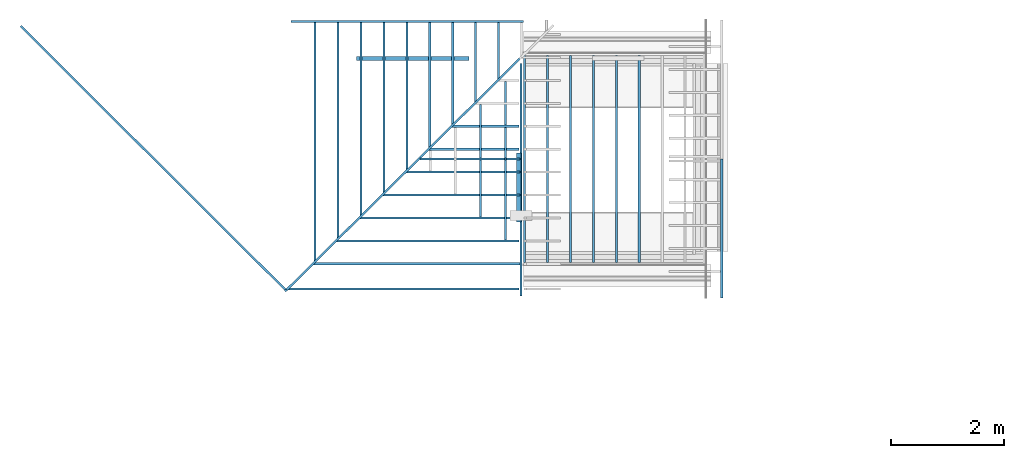
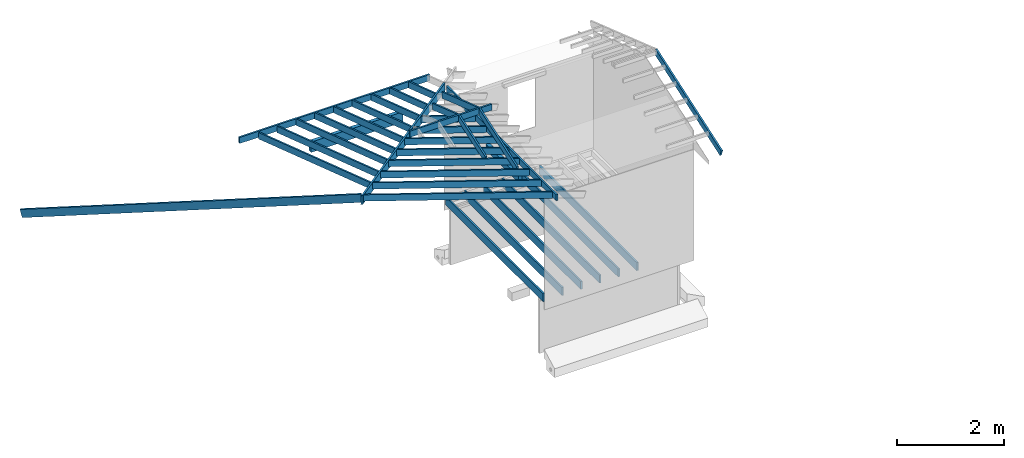
# Not in any storey, part 2 of 8: 35 beams.
"""IFC4 model written with IfcOpenShell, lengths in feet."""

from ifc_helpers import new_model, entity, si_unit, converted_unit, frame, origin_with_axes, origin_2d_with_axis, place, context, subcontext, project, rectangle, extrude, clip, halfspace, material, material_profile, profile_set, profile_usage, type_object, element, save


model = new_model("IFC4")

# Units and contexts
model_context = context("Model", 3, precision=1e-05, world=origin_with_axes())
plan_context = context("Plan", 2, precision=1e-05, world=origin_2d_with_axis())
context_of_model_1 = context(None, 3, precision=1e-05, world=origin_with_axes())
context_of_model_2 = context(None, 3, precision=1e-05, world=origin_with_axes())
body_context = subcontext(model_context, "Body", "Model", "MODEL_VIEW")
ifc_project = project(units=[converted_unit("PLANEANGLEUNIT", "degree", entity("IfcReal", 0.0174532925199433), si_unit("PLANEANGLEUNIT", "RADIAN"), dimensions=[0, 0, 0, 0, 0, 0, 0]), converted_unit("AREAUNIT", "square foot", entity("IfcReal", 0.09290304), si_unit("AREAUNIT", "SQUARE_METRE"), dimensions=[2, 0, 0, 0, 0, 0, 0]), converted_unit("LENGTHUNIT", "foot", entity("IfcReal", 0.3048), si_unit("LENGTHUNIT", "METRE"), dimensions=[1, 0, 0, 0, 0, 0, 0]), converted_unit("VOLUMEUNIT", "cubic foot", entity("IfcReal", 0.0283168467116885), si_unit("VOLUMEUNIT", "CUBIC_METRE"), dimensions=[3, 0, 0, 0, 0, 0, 0])], contexts=[model_context, plan_context, context_of_model_1, context_of_model_2])

# Beams
ifc_material_1 = material(Name="006")
ifc_material_profile_1 = material_profile(ifc_material_1, rectangle(XDim=0.125, YDim=0.604166686534882))
ifc_profile_set_1 = profile_set([ifc_material_profile_1])
ifc_profile_usage_1 = profile_usage(ifc_profile_set_1, cardinal=5)
beam_type_1 = type_object("IfcBeamType", Name="2x8", PredefinedType="BEAM", material=ifc_profile_set_1)
beam_1_placement = place(None, frame((-24.3661660221931, -5.03533664025034, 13.1159348124907), z_axis=(-0.690051735201045, 0.687267125403387, -0.226919591674655), x_axis=(-0.705675718596325, -0.708534953395779, 3.42501741274506e-08)))
element("IfcBeam", 1, at=beam_1_placement, type_object=beam_type_1, material=ifc_profile_usage_1, Name="Beam", context=body_context, shape_type="Clipping", body=[
    clip(extrude(rectangle(XDim=0.125, YDim=0.604166686534882), origin_with_axes(), (0.0, 0.0, 1.0), 22.830093170439), halfspace(frame((-0.000393945028106474, 0.0141815250627012, 0.600858036614466), z_axis=(0.00629699230194092, -0.22691510617733, -0.973894238471985), x_axis=(-0.973805546760559, -0.222762063145638, 0.0456066280603409)), False)),
])
ifc_profile_usage_2 = profile_usage(ifc_profile_set_1, cardinal=5)
beam_2_placement = place(None, frame((-24.7387873531952, -4.66421833188515, 12.8280216940432), z_axis=(0.691535772575133, 0.685647846935964, -0.227300033526156), x_axis=(-0.704077230942166, 0.710123406788434, -2.06514179758879e-08)))
element("IfcBeam", 2, at=beam_2_placement, type_object=beam_type_1, material=ifc_profile_usage_2, Name="Beam", context=body_context, shape_type="SweptSolid", body=[
    extrude(rectangle(XDim=0.125, YDim=0.604166686534882), origin_with_axes(), (0.0, 0.0, 1.0), 19.7270295812514),
])
ifc_material_2 = material(Category="wood3")
ifc_material_profile_2 = material_profile(ifc_material_2, rectangle(XDim=0.125, YDim=0.458299994468689))
ifc_profile_set_2 = profile_set([ifc_material_profile_2])
ifc_profile_usage_3 = profile_usage(ifc_profile_set_2, cardinal=5)
beam_type_2 = type_object("IfcBeamType", Name="2x6 RAFTER", PredefinedType="BEAM", material=ifc_profile_set_2)
beam_3_placement = place(None, frame((-12.3791556971593, 11.3530398353817, 7.58101229905456), z_axis=(-1.19209318326683e-07, -0.948710682826727, 0.316145599827723), x_axis=(0.999999999999993, -1.13095140363838e-07, 3.76875313179423e-08)))
element("IfcBeam", 3, at=beam_3_placement, type_object=beam_type_2, material=ifc_profile_usage_3, Name="Beam", context=body_context, shape_type="Clipping", body=[
    clip(clip(extrude(rectangle(XDim=0.125, YDim=0.458299994468689), origin_with_axes(), (0.0, 0.0, 1.0), 4.33181764302887), halfspace(frame((1.46057642507428, 0.0117523620134889, 0.462216175994848), z_axis=(-2.36881696480395e-08, 0.316145688295364, -0.948710680007935), x_axis=(0.999999999999997, 7.49280174458948e-08, 0.0)), False)), halfspace(frame((1.23831005938097, -0.0278237141336356, 2.57010261217753), z_axis=(0.704077363014221, -0.224502399563789, 0.673701584339142), x_axis=(-0.303790687835165, -0.952738798404178, 0.0)), False)),
])
ifc_profile_usage_4 = profile_usage(ifc_profile_set_2, cardinal=5)
beam_4_placement = place(None, frame((-13.7124896988155, 11.3530398353817, 7.58101229905456), z_axis=(-1.19209318326683e-07, -0.948710682826727, 0.316145599827723), x_axis=(0.999999999999993, -1.13095140363838e-07, 3.76875313179423e-08)))
element("IfcBeam", 4, at=beam_4_placement, type_object=beam_type_2, material=ifc_profile_usage_4, Name="Beam", context=body_context, shape_type="Clipping", body=[
    clip(clip(extrude(rectangle(XDim=0.125, YDim=0.458299994468689), origin_with_axes(), (0.0, 0.0, 1.0), 5.72526768588302), halfspace(frame((2.79391120894375, 0.0117523620134889, 0.462216175994848), z_axis=(-2.36881696480395e-08, 0.316145688295364, -0.948710680007935), x_axis=(0.999999999999997, 7.49280174458948e-08, 0.0)), False)), halfspace(frame((2.57164474547379, -0.0278237141336356, 2.57010261217753), z_axis=(0.704077363014221, -0.224502399563789, 0.673701584339142), x_axis=(-0.303790687835165, -0.952738798404178, 0.0)), False)),
])
ifc_profile_usage_5 = profile_usage(ifc_profile_set_2, cardinal=5)
beam_5_placement = place(None, frame((-15.0458221360454, 11.3530398353817, 7.58101229905456), z_axis=(-1.19209318326683e-07, -0.948710682826727, 0.316145599827723), x_axis=(0.999999999999993, -1.13095140363838e-07, 3.76875313179423e-08)))
element("IfcBeam", 5, at=beam_5_placement, type_object=beam_type_2, material=ifc_profile_usage_5, Name="Beam", context=body_context, shape_type="Clipping", body=[
    clip(clip(extrude(rectangle(XDim=0.125, YDim=0.458299994468689), origin_with_axes(), (0.0, 0.0, 1.0), 7.1187171069876), halfspace(frame((4.12724384172695, 0.0117523620134889, 0.462216175994848), z_axis=(-2.36881696480395e-08, 0.316145688295364, -0.948710680007935), x_axis=(0.999999999999997, 7.49280174458948e-08, 0.0)), False)), halfspace(frame((3.90497718270369, -0.0278237141336356, 2.57010261217753), z_axis=(0.704077363014221, -0.224502399563789, 0.673701584339142), x_axis=(-0.303790687835165, -0.952738798404178, 0.0)), False)),
])
ifc_profile_usage_6 = profile_usage(ifc_profile_set_2, cardinal=5)
beam_6_placement = place(None, frame((-16.3791561377017, 11.3530406175949, 7.58101229905456), z_axis=(-1.19209318326683e-07, -0.948710682826727, 0.316145599827723), x_axis=(0.999999999999993, -1.13095140363838e-07, 3.76875313179423e-08)))
element("IfcBeam", 6, at=beam_6_placement, type_object=beam_type_2, material=ifc_profile_usage_6, Name="Beam", context=body_context, shape_type="Clipping", body=[
    clip(clip(extrude(rectangle(XDim=0.125, YDim=0.458299994468689), origin_with_axes(), (0.0, 0.0, 1.0), 8.51217022524412), halfspace(frame((5.46057784338323, 0.0117523620134889, 0.462216958208034), z_axis=(-2.36881696480395e-08, 0.316145688295364, -0.948710680007935), x_axis=(0.999999999999997, 7.49280174458948e-08, 0.0)), False)), halfspace(frame((5.23831118435997, -0.0278237141336356, 2.57010339439072), z_axis=(0.704077363014221, -0.224502399563789, 0.673701584339142), x_axis=(-0.303790687835165, -0.952738798404178, 0.0)), False)),
])
ifc_profile_usage_7 = profile_usage(ifc_profile_set_2, cardinal=5)
beam_7_placement = place(None, frame((-17.712490139358, 11.3530406175949, 7.58101151684138), z_axis=(-1.19209318326683e-07, -0.948710682826727, 0.316145599827723), x_axis=(0.999999999999993, -1.13095140363838e-07, 3.76875313179423e-08)))
element("IfcBeam", 7, at=beam_7_placement, type_object=beam_type_2, material=ifc_profile_usage_7, Name="Beam", context=body_context, shape_type="Clipping", body=[
    clip(clip(extrude(rectangle(XDim=0.125, YDim=0.458299994468689), origin_with_axes(), (0.0, 0.0, 1.0), 9.9056214970809), halfspace(frame((6.79391184503951, 0.0117523620134889, 0.462216958208034), z_axis=(-2.36881696480395e-08, 0.316145688295364, -0.948710680007935), x_axis=(0.999999999999997, 7.49280174458948e-08, 0.0)), False)), halfspace(frame((6.57164518601625, -0.0278237141336356, 2.57010339439072), z_axis=(0.704077363014221, -0.224502399563789, 0.673701584339142), x_axis=(-0.303790687835165, -0.952738798404178, 0.0)), False)),
])
ifc_profile_usage_8 = profile_usage(ifc_profile_set_2, cardinal=5)
beam_8_placement = place(None, frame((-19.0458225765879, 11.3530406175949, 7.58101151684138), z_axis=(-1.19209318326683e-07, -0.948710682826727, 0.316145599827723), x_axis=(0.999999999999993, -1.13095140363838e-07, 3.76875313179423e-08)))
element("IfcBeam", 8, at=beam_8_placement, type_object=beam_type_2, material=ifc_profile_usage_8, Name="Beam", context=body_context, shape_type="Clipping", body=[
    clip(clip(extrude(rectangle(XDim=0.125, YDim=0.458299994468689), origin_with_axes(), (0.0, 0.0, 1.0), 11.2990715346469), halfspace(frame((8.12724428226941, 0.0117523620134889, 0.462216175994848), z_axis=(-2.36881696480395e-08, 0.316145688295364, -0.948710680007935), x_axis=(0.999999999999997, 7.49280174458948e-08, 0.0)), False)), halfspace(frame((7.90497762324616, -0.0278237141336356, 2.57010261217753), z_axis=(0.704077363014221, -0.224502399563789, 0.673701584339142), x_axis=(-0.303790687835165, -0.952738798404178, 0.0)), False)),
])
ifc_profile_usage_9 = profile_usage(ifc_profile_set_2, cardinal=5)
beam_9_placement = place(None, frame((-20.3791565782442, 11.3530406175949, 7.58101151684138), z_axis=(-1.19209318326683e-07, -0.948710682826727, 0.316145599827723), x_axis=(0.999999999999993, -1.13095140363838e-07, 3.76875313179423e-08)))
element("IfcBeam", 9, at=beam_9_placement, type_object=beam_type_2, material=ifc_profile_usage_9, Name="Beam", context=body_context, shape_type="Clipping", body=[
    clip(clip(extrude(rectangle(XDim=0.125, YDim=0.458299994468689), origin_with_axes(), (0.0, 0.0, 1.0), 12.6925213004818), halfspace(frame((9.46057828392569, 0.0117523620134889, 0.462216175994848), z_axis=(-2.36881696480395e-08, 0.316145688295364, -0.948710680007935), x_axis=(0.999999999999997, 7.49280174458948e-08, 0.0)), False)), halfspace(frame((9.23831162490244, -0.0278237141336356, 2.57010261217753), z_axis=(0.704077363014221, -0.224502399563789, 0.673701584339142), x_axis=(-0.303790687835165, -0.952738798404178, 0.0)), False)),
])
ifc_profile_usage_10 = profile_usage(ifc_profile_set_2, cardinal=5)
beam_10_placement = place(None, frame((-21.7124890154741, 11.3530406175949, 7.4886368328505), z_axis=(-1.19209318326683e-07, -0.948710682826727, 0.316145599827723), x_axis=(0.999999999999993, -1.13095140363838e-07, 3.76875313179423e-08)))
element("IfcBeam", 10, at=beam_10_placement, type_object=beam_type_2, material=ifc_profile_usage_10, Name="Beam", context=body_context, shape_type="Clipping", body=[
    clip(clip(extrude(rectangle(XDim=0.125, YDim=0.458299994468689), origin_with_axes(), (0.0, 0.0, 1.0), 14.0859698504122), halfspace(frame((10.7939107211556, 0.0993899629497778, 0.491420105295231), z_axis=(-2.36881696480395e-08, 0.316145688295364, -0.948710680007935), x_axis=(0.999999999999997, 7.49280174458948e-08, 0.0)), False)), halfspace(frame((10.5716440621323, 0.0598138868026533, 2.59930654147791), z_axis=(0.704077363014221, -0.224502399563789, 0.673701584339142), x_axis=(-0.303790687835165, -0.952738798404178, 0.0)), False)),
])
ifc_profile_usage_11 = profile_usage(ifc_profile_set_2, cardinal=5)
beam_11_placement = place(None, frame((-10.7543893999315, 4.88486620071992, 8.28830041284636), z_axis=(-0.948710682826718, -1.82218031427762e-07, 0.316145599827721), x_axis=(-1.62920684942944e-07, 0.999999999999983, 8.74705818887363e-08)))
element("IfcBeam", 11, at=beam_11_placement, type_object=beam_type_2, material=ifc_profile_usage_11, Name="Beam", context=body_context, shape_type="Clipping", body=[
    clip(clip(extrude(rectangle(XDim=0.125, YDim=0.458299994468689), origin_with_axes(), (0.0, 0.0, 1.0), 4.95339397692722), halfspace(frame((-9.87245654809506, 0.0240000987210338, 0.450305415811188), z_axis=(-3.13916473260178e-07, -0.316145569086075, -0.94871062040329), x_axis=(-0.999999999999507, 9.92949147342172e-07, 0.0)), False)), halfspace(frame((3.93232726675319, 0.0195552165964692, 0.308063467891197), z_axis=(0.710123538970947, 0.22259096801281, 0.667965531349182), x_axis=(0.299104099787267, -0.954220486832288, 0.0)), False)),
])
ifc_profile_usage_12 = profile_usage(ifc_profile_set_2, cardinal=5)
beam_12_placement = place(None, frame((-10.7543893999315, 3.55153259017023, 8.28830197727273), z_axis=(-0.948710682826718, -1.82218031427762e-07, 0.316145599827721), x_axis=(-1.62920684942944e-07, 0.999999999999983, 8.74705818887363e-08)))
element("IfcBeam", 12, at=beam_12_placement, type_object=beam_type_2, material=ifc_profile_usage_12, Name="Beam", context=body_context, shape_type="Clipping", body=[
    clip(clip(extrude(rectangle(XDim=0.125, YDim=0.458299994468689), origin_with_axes(), (0.0, 0.0, 1.0), 6.37087815891697), halfspace(frame((-8.53912254643878, 0.0240012720408128, 0.450304633598002), z_axis=(-3.13916473260178e-07, -0.316145569086075, -0.94871062040329), x_axis=(-0.999999999999507, 9.92949147342172e-07, 0.0)), False)), halfspace(frame((5.26566087730288, 0.0195563899162482, 0.308062685678011), z_axis=(0.710123538970947, 0.22259096801281, 0.667965531349182), x_axis=(0.299104099787267, -0.954220486832288, 0.0)), False)),
])
ifc_profile_usage_13 = profile_usage(ifc_profile_set_2, cardinal=5)
beam_13_placement = place(None, frame((-10.6918897841546, 0.884866249060693, 8.26747320455516), z_axis=(-0.948710682826718, -1.82218031427762e-07, 0.316145599827721), x_axis=(-1.62920684942944e-07, 0.999999999999983, 8.74705818887363e-08)))
element("IfcBeam", 13, at=beam_13_placement, type_object=beam_type_2, material=ifc_profile_usage_13, Name="Beam", context=body_context, shape_type="Clipping", body=[
    clip(clip(extrude(rectangle(XDim=0.125, YDim=0.458299994468689), origin_with_axes(), (0.0, 0.0, 1.0), 9.27172909024728), halfspace(frame((-5.8724561075526, 0.00424022070410859, 0.456888521984806), z_axis=(-3.13916473260178e-07, -0.316145569086075, -0.94871062040329), x_axis=(-0.999999999999507, 9.92949147342172e-07, 0.0)), False)), halfspace(frame((7.93232770729565, 0.0195548254898762, 0.373941462418539), z_axis=(0.710123538970947, 0.22259096801281, 0.667965531349182), x_axis=(0.299104099787267, -0.954220486832288, 0.0)), False)),
])
ifc_profile_usage_14 = profile_usage(ifc_profile_set_2, cardinal=5)
beam_14_placement = place(None, frame((-10.7543901821447, -1.78180009204885, 8.28830510612548), z_axis=(-0.948710682826718, -1.82218031427762e-07, 0.316145599827721), x_axis=(-1.62920684942944e-07, 0.999999999999983, 8.74705818887363e-08)))
element("IfcBeam", 14, at=beam_14_placement, type_object=beam_type_2, material=ifc_profile_usage_14, Name="Beam", context=body_context, shape_type="Clipping", body=[
    clip(clip(extrude(rectangle(XDim=0.125, YDim=0.458299994468689), origin_with_axes(), (0.0, 0.0, 1.0), 12.040817740485), halfspace(frame((-3.20578986421971, 0.02400479200015, 0.450302286958444), z_axis=(-3.13916473260178e-07, -0.316145569086075, -0.94871062040329), x_axis=(-0.999999999999507, 9.92949147342172e-07, 0.0)), False)), halfspace(frame((10.5989941461818, 0.0195599098755853, 0.308060339038453), z_axis=(0.710123538970947, 0.22259096801281, 0.667965531349182), x_axis=(0.299104099787267, -0.954220486832288, 0.0)), False)),
])
ifc_profile_usage_15 = profile_usage(ifc_profile_set_2, cardinal=5)
beam_15_placement = place(None, frame((-10.6918905663678, -3.11513311593864, 8.26747164012879), z_axis=(-0.948710682826718, -1.82218031427762e-07, 0.316145599827721), x_axis=(-1.62920684942944e-07, 0.999999999999983, 8.74705818887363e-08)))
element("IfcBeam", 15, at=beam_15_placement, type_object=beam_type_2, material=ifc_profile_usage_15, Name="Beam", context=body_context, shape_type="Clipping", body=[
    clip(clip(extrude(rectangle(XDim=0.125, YDim=0.458299994468689), origin_with_axes(), (0.0, 0.0, 1.0), 13.5241826288836), halfspace(frame((-1.87245684032991, 0.00423865627773654, 0.45688773977162), z_axis=(-3.13916473260178e-07, -0.316145569086075, -0.94871062040329), x_axis=(-0.999999999999507, 9.92949147342172e-07, 0.0)), False)), halfspace(frame((11.9323265834117, 0.0195532610635041, 0.373940680205353), z_axis=(0.710123538970947, 0.22259096801281, 0.667965531349182), x_axis=(0.299104099787267, -0.954220486832288, 0.0)), False)),
])
ifc_profile_usage_16 = profile_usage(ifc_profile_set_2, cardinal=5)
beam_16_placement = place(None, frame((-10.7543909643579, -4.57346674025528, 8.28830041284636), z_axis=(-0.948710682826718, -1.82218031427762e-07, 0.316145599827721), x_axis=(-1.62920684942944e-07, 0.999999999999983, 8.74705818887363e-08)))
element("IfcBeam", 16, at=beam_16_placement, type_object=beam_type_2, material=ifc_profile_usage_16, Name="Beam", context=body_context, shape_type="Clipping", body=[
    clip(clip(extrude(rectangle(XDim=0.125, YDim=0.458299994468689), origin_with_axes(), (0.0, 0.0, 1.0), 15.0086755524477), halfspace(frame((-0.414123020459974, 0.0239997076144408, 0.450302286958444), z_axis=(-3.13916473260178e-07, -0.316145569086075, -0.94871062040329), x_axis=(-0.999999999999507, 9.92949147342172e-07, 0.0)), False)), halfspace(frame((13.390660598835, 0.0195548254898762, 0.308060339038453), z_axis=(0.710123538970947, 0.22259096801281, 0.667965531349182), x_axis=(0.299104099787267, -0.954220486832288, 0.0)), False)),
])
ifc_profile_usage_17 = profile_usage(ifc_profile_set_2, cardinal=5)
beam_17_placement = place(None, frame((-10.6918897841546, -0.448467361488993, 8.28830510612548), z_axis=(-0.948710682826718, -1.82218031427762e-07, 0.316145599827721), x_axis=(-1.62920684942944e-07, 0.999999999999983, 8.74705818887363e-08)))
element("IfcBeam", 17, at=beam_17_placement, type_object=beam_type_2, material=ifc_profile_usage_17, Name="Beam", context=body_context, shape_type="Clipping", body=[
    clip(clip(extrude(rectangle(XDim=0.125, YDim=0.458299994468689), origin_with_axes(), (0.0, 0.0, 1.0), 10.6892148754712), halfspace(frame((-4.5391228881095, 0.00423943849092256, 0.456888521984806), z_axis=(-3.13916473260178e-07, -0.316145569086075, -0.94871062040329), x_axis=(-0.999999999999507, 9.92949147342172e-07, 0.0)), False)), halfspace(frame((-4.26013130215522, 0.100311263417947, 14.7264929894074), z_axis=(0.710123538970947, 0.22259096801281, 0.667965531349182), x_axis=(0.299104099787267, -0.954220486832288, 0.0)), False)),
])
ifc_profile_usage_18 = profile_usage(ifc_profile_set_2, cardinal=5)
beam_18_placement = place(None, frame((-10.6918897841546, 2.21820034849362, 8.26747242234197), z_axis=(-0.948710682826718, -1.82218031427762e-07, 0.316145599827721), x_axis=(-1.62920684942944e-07, 0.999999999999983, 8.74705818887363e-08)))
element("IfcBeam", 18, at=beam_18_placement, type_object=beam_type_2, material=ifc_profile_usage_18, Name="Beam", context=body_context, shape_type="Clipping", body=[
    clip(clip(extrude(rectangle(XDim=0.125, YDim=0.458299994468689), origin_with_axes(), (0.0, 0.0, 1.0), 7.85424459943311), halfspace(frame((-6.92679891436119, 0.100311263417947, 14.7264929894074), z_axis=(0.710123538970947, 0.22259096801281, 0.667965531349182), x_axis=(0.299104099787267, -0.954220486832288, 0.0)), False)), halfspace(frame((-7.20579010920888, 0.00423943849092256, 0.456888521984806), z_axis=(-3.13916473260178e-07, -0.316145569086075, -0.94871062040329), x_axis=(-0.999999999999507, 9.92949147342172e-07, 0.0)), False)),
])
ifc_profile_usage_19 = profile_usage(ifc_profile_set_2, cardinal=5)
beam_19_placement = place(None, frame((-23.0458183238513, 11.3530406175949, 7.4886368328505), z_axis=(-1.19209318326683e-07, -0.948710682826727, 0.316145599827723), x_axis=(0.999999999999993, -1.13095140363838e-07, 3.7687534870656e-08)))
element("IfcBeam", 19, at=beam_19_placement, type_object=beam_type_2, material=ifc_profile_usage_19, Name="Beam", context=body_context, shape_type="Clipping", body=[
    clip(clip(extrude(rectangle(XDim=0.125, YDim=0.458299994468689), origin_with_axes(), (0.0, 0.0, 1.0), 15.4794149845216), halfspace(frame((12.1272400295328, 0.0993899629497778, 0.491420105295231), z_axis=(-2.36881696480395e-08, 0.316145688295364, -0.948710680007935), x_axis=(0.999999999999997, 7.49280174458948e-08, 0.0)), False)), halfspace(frame((-1.73697067214435, 0.0157772399621999, 16.8416615859104), z_axis=(0.704077363014221, -0.224502399563789, 0.673701584339142), x_axis=(-0.303790687835165, -0.952738798404178, 0.0)), False)),
])
ifc_material_profile_3 = material_profile(ifc_material_2, rectangle(XDim=0.125, YDim=0.458299994468689))
ifc_profile_set_3 = profile_set([ifc_material_profile_3])
ifc_profile_usage_20 = profile_usage(ifc_profile_set_3, cardinal=5)
beam_type_3 = type_object("IfcBeamType", Name="2X6 BARGE RAFTER", PredefinedType="BEAM", material=ifc_profile_set_3)
beam_20_placement = place(None, frame((0.60698335252096, -5.02524061465827, 7.70262376529964), z_axis=(8.54136783382466e-07, 0.94649584365125, 0.322716002005138), x_axis=(-0.999999999999619, 8.6625152562159e-07, 1.06078630324151e-07)))
element("IfcBeam", 20, at=beam_20_placement, type_object=beam_type_3, material=ifc_profile_usage_20, Name="Beam", context=body_context, shape_type="Clipping", body=[
    clip(extrude(rectangle(XDim=0.125, YDim=0.458299994468689), origin_with_axes(), (0.0, 0.0, 1.0), 9.29634651111038), halfspace(frame((0.606990783546227, 0.229148375080639, 8.54114300309829), z_axis=(5.88725526995404e-07, -0.32276913523674, 0.946477711200714), x_axis=(-0.999999999998337, -1.82398334513185e-06, 0.0)), False)),
])
ifc_profile_usage_21 = profile_usage(ifc_profile_set_3, cardinal=5)
beam_21_placement = place(None, frame((-11.9763487593083, 7.92279487519752, 8.74954180454645), z_axis=(-1.19209291908779e-07, -0.946459133272804, 0.322823650069941), x_axis=(0.999999999999993, -1.12826725739978e-07, 3.84835772138101e-08)))
element("IfcBeam", 21, at=beam_21_placement, type_object=beam_type_3, material=ifc_profile_usage_21, Name="Beam", context=body_context, shape_type="Clipping", body=[
    clip(clip(extrude(rectangle(XDim=0.125, YDim=0.458299994468689), origin_with_axes(), (0.0, 0.0, 1.0), 5.61099506428816), halfspace(frame((1.28446005069678, -0.596286782755314, 0.254914966311668), z_axis=(-2.6183835188931e-07, 0.322823762893677, -0.946459233760834), x_axis=(0.999999999999671, 8.11087602542633e-07, 0.0)), False)), halfspace(frame((-4.9841834178434, 0.0204078442468418, 5.15965612854545), z_axis=(-6.38255670537546e-09, -0.32282367348671, 0.946459233760834), x_axis=(-1.0, 1.97710305332927e-08, 0.0)), False)),
])
ifc_profile_usage_22 = profile_usage(ifc_profile_set_3, cardinal=5)
beam_22_placement = place(None, frame((-11.9763448482423, -2.15307934077706, 8.68191087026921), z_axis=(7.93965181543928e-07, 0.946495843651296, 0.322716002005154), x_axis=(-0.999999999999672, 8.02678528088755e-07, 1.06078694273003e-07)))
element("IfcBeam", 22, at=beam_22_placement, type_object=beam_type_3, material=ifc_profile_usage_22, Name="Beam", context=body_context, shape_type="Clipping", body=[
    clip(extrude(rectangle(XDim=0.125, YDim=0.458299994468689), origin_with_axes(), (0.0, 0.0, 1.0), 5.43901758544511), halfspace(frame((-1.28445721517398, -0.532248064758271, 0.27682661540865), z_axis=(-1.0152631375604e-06, 0.322715908288956, -0.946495831012726), x_axis=(0.999999999995051, 3.14599656068494e-06, 0.0)), False)),
])
ifc_profile_usage_23 = profile_usage(ifc_profile_set_3, cardinal=5)
beam_23_placement = place(None, frame((-13.4346804280919, 6.58946087354124, 9.20432289754312), z_axis=(-1.19209291908779e-07, -0.946459133272804, 0.322823650069941), x_axis=(0.999999999999993, -1.12826725739978e-07, 3.84835772138101e-08)))
element("IfcBeam", 23, at=beam_23_placement, type_object=beam_type_3, material=ifc_profile_usage_23, Name="Beam", context=body_context, shape_type="Clipping", body=[
    clip(clip(extrude(rectangle(XDim=0.125, YDim=0.458299994468689), origin_with_axes(), (0.0, 0.0, 1.0), 4.20223436757718), halfspace(frame((2.74279259947028, -1.0267181659308, 0.10809980899956), z_axis=(-2.6183835188931e-07, 0.322823762893677, -0.946459233760834), x_axis=(0.999999999999671, 8.11087602542633e-07, 0.0)), False)), halfspace(frame((-3.52585096684654, 0.0204078442468418, 3.75089565599997), z_axis=(-6.38255670537546e-09, -0.32282367348671, 0.946459233760834), x_axis=(-1.0, 1.97710305332927e-08, 0.0)), False)),
])
ifc_profile_usage_24 = profile_usage(ifc_profile_set_3, cardinal=5)
beam_24_placement = place(None, frame((-13.4346772992392, -0.819746512440559, 9.13652378743089), z_axis=(8.54136783382466e-07, 0.94649584365125, 0.322716002005138), x_axis=(-0.999999999999619, 8.6625152562159e-07, 1.06078672956715e-07)))
element("IfcBeam", 24, at=beam_24_placement, type_object=beam_type_3, material=ifc_profile_usage_24, Name="Beam", context=body_context, shape_type="Clipping", body=[
    clip(clip(extrude(rectangle(XDim=0.125, YDim=0.458299994468689), origin_with_axes(), (0.0, 0.0, 1.0), 4.41048510118521), halfspace(frame((-2.74278692842468, -0.962541485083072, 0.130116066888092), z_axis=(-1.0152631375604e-06, 0.322715908288956, -0.946495831012726), x_axis=(0.999999999995051, 3.14599656068494e-06, 0.0)), False)), halfspace(frame((3.52585918008499, 0.0213515920945861, 3.95946145996334), z_axis=(7.47042236071138e-07, -0.322715997695923, 0.946495831012726), x_axis=(-0.999999999997321, -2.31485963324642e-06, 0.0)), False)),
])
ifc_material_profile_4 = material_profile(ifc_material_2, rectangle(XDim=0.125, YDim=0.458299994468689))
ifc_profile_set_4 = profile_set([ifc_material_profile_4])
ifc_profile_usage_25 = profile_usage(ifc_profile_set_4, cardinal=5)
beam_type_4 = type_object("IfcBeamType", Name="2x6 RAFTER Copy", PredefinedType="BEAM", material=ifc_profile_set_4)
beam_25_placement = place(None, frame((-16.9605329593648, 2.98348037902452, 10.4345150507028), z_axis=(0.999999999999994, -7.54979012640429e-08, 7.54979012640429e-08), x_axis=(7.54979012640431e-08, 0.999999999999997, 7.16093850883224e-15)))
element("IfcBeam", 25, at=beam_25_placement, type_object=beam_type_4, material=ifc_profile_usage_25, Name="Beam", context=body_context, shape_type="SweptSolid", body=[
    extrude(rectangle(XDim=0.125, YDim=0.458299994468689), origin_with_axes(), (0.0, 0.0, 1.0), 5.83794183555856),
])
ifc_material_3 = material(Name="(2) 2X6 HEADER", Category="wood3")
ifc_material_profile_5 = material_profile(ifc_material_3, rectangle(XDim=0.25, YDim=0.458332985639572))
ifc_profile_set_5 = profile_set([ifc_material_profile_5])
ifc_profile_usage_26 = profile_usage(ifc_profile_set_5, cardinal=5)
beam_type_5 = type_object("IfcBeamType", Name="(2) 2X6 HEADER", PredefinedType="BEAM", material=ifc_profile_set_5)
beam_26_placement = place(None, frame((-11.1981639711876, 3.32251034696584, 7.26326087641278), z_axis=(-1.19209282445353e-07, -0.99999999999999, 7.54979012640426e-08), x_axis=(0.999999999999993, -1.19209282445353e-07, -5.02429578180088e-15)))
element("IfcBeam", 26, at=beam_26_placement, type_object=beam_type_5, material=ifc_profile_usage_26, Name="Beam", context=body_context, shape_type="SweptSolid", body=[
    extrude(rectangle(XDim=0.25, YDim=0.458332985639572), origin_with_axes(), (0.0, 0.0, 1.0), 4.00000000752369),
])
ifc_material_4 = material(Category="wood3")
ifc_material_profile_6 = material_profile(ifc_material_4, rectangle(XDim=0.125, YDim=0.604166686534882))
ifc_profile_set_6 = profile_set([ifc_material_profile_6])
ifc_profile_usage_27 = profile_usage(ifc_profile_set_6, cardinal=5)
beam_type_6 = type_object("IfcBeamType", Name="2x8 JOIST", PredefinedType="BEAM", material=ifc_profile_set_6)
beam_27_placement = place(None, frame((-4.19205450636195, -3.03462382376663, -0.364615476819787), z_axis=(1.50995802528084e-07, 0.999999999999986, 7.54979012640422e-08), x_axis=(-0.999999999999989, 1.50995802528085e-07, 1.00485924106347e-14)))
element("IfcBeam", 27, at=beam_27_placement, type_object=beam_type_6, material=ifc_profile_usage_27, Name="Beam", context=body_context, shape_type="SweptSolid", body=[
    extrude(rectangle(XDim=0.125, YDim=0.604166686534882), origin_with_axes(), (0.0, 0.0, 1.0), 12.0362051546511),
])
ifc_profile_usage_28 = profile_usage(ifc_profile_set_6, cardinal=5)
beam_28_placement = place(None, frame((-5.5253845969523, -3.03462362821334, -0.364615476819787), z_axis=(1.50995802528084e-07, 0.999999999999986, 7.54979012640422e-08), x_axis=(-0.999999999999989, 1.50995802528085e-07, 1.00485924106347e-14)))
element("IfcBeam", 28, at=beam_28_placement, type_object=beam_type_6, material=ifc_profile_usage_28, Name="Beam", context=body_context, shape_type="SweptSolid", body=[
    extrude(rectangle(XDim=0.125, YDim=0.604166686534882), origin_with_axes(), (0.0, 0.0, 1.0), 12.0362043017855),
])
ifc_profile_usage_29 = profile_usage(ifc_profile_set_6, cardinal=5)
beam_29_placement = place(None, frame((-6.85871429643606, -3.03462343266004, -0.364615476819787), z_axis=(1.50995802528084e-07, 0.999999999999986, 7.54979012640422e-08), x_axis=(-0.999999999999989, 1.50995802528085e-07, 1.00485924106347e-14)))
element("IfcBeam", 29, at=beam_29_placement, type_object=beam_type_6, material=ifc_profile_usage_29, Name="Beam", context=body_context, shape_type="SweptSolid", body=[
    extrude(rectangle(XDim=0.125, YDim=0.604166686534882), origin_with_axes(), (0.0, 0.0, 1.0), 12.0362043017855),
])
ifc_profile_usage_30 = profile_usage(ifc_profile_set_6, cardinal=5)
beam_30_placement = place(None, frame((-8.19204438702641, -3.03462323710674, -0.364615476819787), z_axis=(1.50995802528084e-07, 0.999999999999986, 7.54979012640422e-08), x_axis=(-0.999999999999989, 1.50995802528085e-07, 1.00485924106347e-14)))
element("IfcBeam", 30, at=beam_30_placement, type_object=beam_type_6, material=ifc_profile_usage_30, Name="Beam", context=body_context, shape_type="SweptSolid", body=[
    extrude(rectangle(XDim=0.125, YDim=0.604166686534882), origin_with_axes(), (0.0, 0.0, 1.0), 12.0362043017855),
])
ifc_profile_usage_31 = profile_usage(ifc_profile_set_6, cardinal=5)
beam_31_placement = place(None, frame((-9.52537447761676, -3.03462304155345, -0.364615476819787), z_axis=(1.50995802528084e-07, 0.999999999999986, 7.54979012640422e-08), x_axis=(-0.999999999999989, 1.50995802528085e-07, 1.00485924106347e-14)))
element("IfcBeam", 31, at=beam_31_placement, type_object=beam_type_6, material=ifc_profile_usage_31, Name="Beam", context=body_context, shape_type="SweptSolid", body=[
    extrude(rectangle(XDim=0.125, YDim=0.604166686534882), origin_with_axes(), (0.0, 0.0, 1.0), 12.0362038753526),
])
ifc_profile_usage_32 = profile_usage(ifc_profile_set_6, cardinal=5)
beam_32_placement = place(None, frame((-10.8587045682071, -3.03462284600015, -0.364615476819787), z_axis=(1.50995802528084e-07, 0.999999999999986, 7.54979012640422e-08), x_axis=(-0.999999999999989, 1.50995802528085e-07, 1.00485924106347e-14)))
element("IfcBeam", 32, at=beam_32_placement, type_object=beam_type_6, material=ifc_profile_usage_32, Name="Beam", context=body_context, shape_type="SweptSolid", body=[
    extrude(rectangle(XDim=0.125, YDim=0.604166686534882), origin_with_axes(), (0.0, 0.0, 1.0), 12.0362043017855),
])
ifc_material_profile_7 = material_profile(ifc_material_2, rectangle(XDim=0.125, YDim=0.458299994468689))
ifc_profile_set_7 = profile_set([ifc_material_profile_7])
ifc_profile_usage_33 = profile_usage(ifc_profile_set_7, cardinal=5)
beam_type_7 = type_object("IfcBeamType", Name="2X6", PredefinedType="BEAM", material=ifc_profile_set_7)
beam_33_placement = place(None, frame((-11.0641849322582, -4.98758995626855, 8.4078929868583), z_axis=(1.50995802528084e-07, 0.999999999999986, 7.54979012640422e-08), x_axis=(-0.999999999999989, 1.50995802528085e-07, 7.16093766179923e-15)))
element("IfcBeam", 33, at=beam_33_placement, type_object=beam_type_7, material=ifc_profile_usage_33, Name="Beam", context=body_context, shape_type="SweptSolid", body=[
    extrude(rectangle(XDim=0.125, YDim=0.458299994468689), origin_with_axes(), (0.0, 0.0, 1.0), 13.5204202563126),
])
ifc_profile_usage_34 = profile_usage(ifc_profile_set_7, cardinal=5)
beam_34_placement = place(None, frame((-10.9185790765317, 10.9807462517045, 7.73828955772981), z_axis=(-0.999999999999997, -1.1924880638503e-08, 7.54979012640431e-08), x_axis=(1.19248806385031e-08, -1.0, 7.16093681476637e-15)))
element("IfcBeam", 34, at=beam_34_placement, type_object=beam_type_7, material=ifc_profile_usage_34, Name="Beam", context=body_context, shape_type="SweptSolid", body=[
    extrude(rectangle(XDim=0.125, YDim=0.458299994468689), origin_with_axes(), (0.0, 0.0, 1.0), 13.5204202563126),
])
ifc_material_5 = material(Name="(2) 2X10 HEADER", Category="wood3")
ifc_material_profile_8 = material_profile(ifc_material_5, rectangle(XDim=0.25, YDim=0.770833015441895))
ifc_profile_set_8 = profile_set([ifc_material_profile_8])
ifc_profile_usage_35 = profile_usage(ifc_profile_set_8, cardinal=5)
beam_type_8 = type_object("IfcBeamType", Name="(2) 2X10 HEADER", PredefinedType="BEAM", material=ifc_profile_set_8)
beam_35_placement = place(None, frame((-20.6373901817742, 8.83190494196934, 7.23620881558716), z_axis=(0.999999999999998, 4.37113882867378e-08, -4.37113882867378e-08), x_axis=(-4.37113882867379e-08, 0.999999999999999, 0.0)))
element("IfcBeam", 35, at=beam_35_placement, type_object=beam_type_8, material=ifc_profile_usage_35, Name="Beam", context=body_context, shape_type="SweptSolid", body=[
    extrude(rectangle(XDim=0.25, YDim=0.770833015441895), origin_with_axes(), (0.0, 0.0, 1.0), 6.5334044388503),
])

save(model, "model.ifc")
